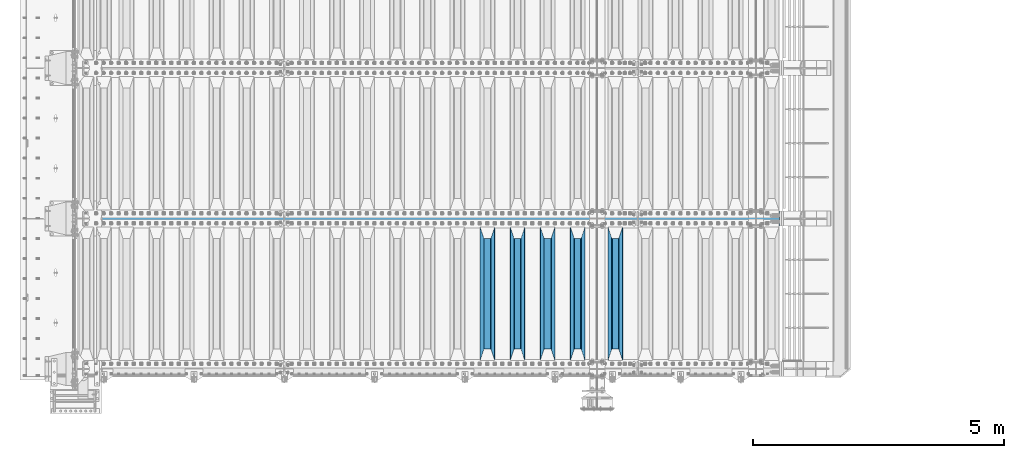
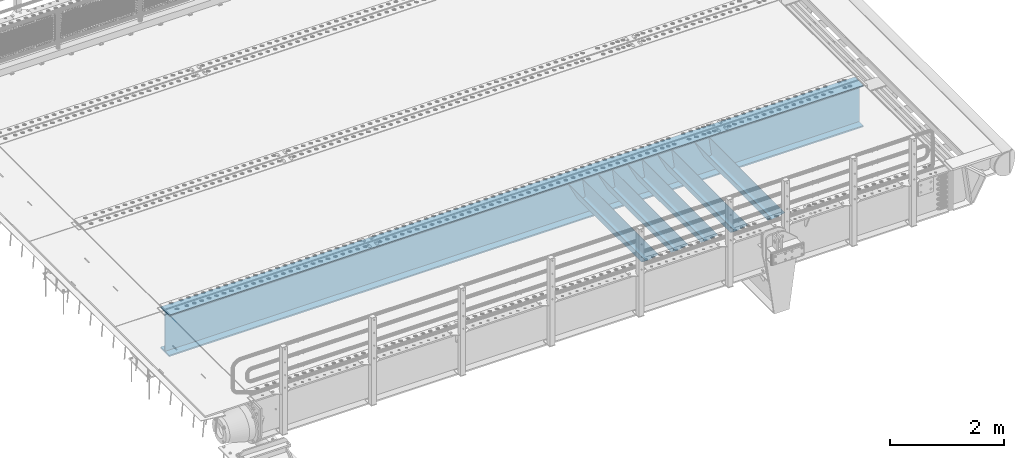
# One storey, part 106 of 240: 6 beams.
"""IFC2X3 building model written with IfcOpenShell, lengths in millimetres."""

from ifc_helpers import new_model, si_unit, frame, origin_with_axes, place, context, subcontext, project, spatial, faceted_brep, material, type_object, element, save


model = new_model("IFC2X3")

# Units and contexts
model_context = context("Model", 3, precision=1e-05, world=origin_with_axes())
body_context = subcontext(model_context, "Body", "Model", "MODEL_VIEW")
ifc_project = project(units=[si_unit("LENGTHUNIT", "METRE", prefix="MILLI"), si_unit("AREAUNIT", "SQUARE_METRE"), si_unit("VOLUMEUNIT", "CUBIC_METRE"), si_unit("MASSUNIT", "GRAM", prefix="KILO"), si_unit("TIMEUNIT", "SECOND"), si_unit("PLANEANGLEUNIT", "RADIAN"), si_unit("SOLIDANGLEUNIT", "STERADIAN"), si_unit("THERMODYNAMICTEMPERATUREUNIT", "DEGREE_CELSIUS"), si_unit("LUMINOUSINTENSITYUNIT", "LUMEN")], contexts=[model_context])

# Site, building, storey
site_placement = place(None, origin_with_axes())
site = spatial("IfcSite", under=ifc_project, at=site_placement, CompositionType="ELEMENT")
building_placement = place(site_placement, origin_with_axes())
building = spatial("IfcBuilding", under=site, at=building_placement, Name="Standard", CompositionType="ELEMENT")
storey_placement = place(building_placement, origin_with_axes())
storey = spatial("IfcBuildingStorey", under=building, at=storey_placement, Name="Undefined", CompositionType="ELEMENT", Elevation=0.0)

# Beams
ifc_material = material(Name="STEEL/S355N")
beam_type_1 = type_object("IfcBeamType", PredefinedType="NOTDEFINED")
beam_1_placement = place(storey_placement, frame((53200.0, 24175.0, -115.0), z_axis=(0.0, 0.0, 1.0), x_axis=(0.0, 1.0, 0.0)))
element("IfcBeam", 1, at=beam_1_placement, inside=storey, type_object=beam_type_1, material=ifc_material, context=body_context, shape_type="Brep", body=[
    faceted_brep([(0.0, 150.0, 115.0), (0.0, 143.690000000002, 115.0), (2650.00000000297, 143.690000000002, 115.0), (2650.00000000297, 150.0, 115.0), (2650.00000000297, 142.059565218406, 110.000000003094), (2650.00000000297, 148.369565218403, 110.000000003094), (2441.90079219209, -80.1103600731149, -98.0992078077845), (2437.7588105432, -77.5672621345584, -102.241189456673), (2434.06523489747, -74.4080125315522, -105.934765102404), (2430.9108609509, -70.7102721255724, -109.089139048974), (2428.37322971128, -66.5649389910031, -111.626770288588), (2426.51472138055, -62.0739139532889, -113.485278619323), (2425.38102192092, -57.3475956567636, -114.618978078955), (2424.99999999987, -52.5021667386536, -115.0), (2424.99999999987, 52.5021667386536, -115.0), (2425.38102192092, 57.3475956567636, -114.618978078955), (2426.51472138055, 62.0739139532889, -113.485278619323), (2428.37322971128, 66.5649389910031, -111.626770288588), (2430.9108609509, 70.7102721255724, -109.089139048974), (2434.06523489747, 74.4080125315522, -105.934765102404), (2437.7588105432, 77.5672621345584, -102.241189456673), (2441.90079219209, 80.1103600731149, -98.0992078077846), (2446.38936140512, 81.9747917625791, -93.6106385947584), (2448.2494850041, 76.2713538057287, -91.7505149957729), (2444.62967112263, 74.76777986261, -95.3703288772456), (2441.28936334127, 72.7168944282894, -98.710636658607), (2438.31067330439, 70.1691124903809, -101.689326695487), (2435.76682334748, 67.1870637758839, -104.233176652398), (2433.72034654134, 63.8440531834931, -106.279653458539), (2432.22154950042, 60.2222587982324, -107.778450499454), (2431.30727574265, 56.4107117849126, -108.692724257221), (2430.99999999987, 52.5031078186876, -109.0), (2430.99999999987, -52.5031078186876, -109.0), (2431.30727574265, -56.4107117849126, -108.692724257221), (2432.22154950042, -60.2222587982324, -107.778450499454), (2433.72034654134, -63.8440531834931, -106.279653458539), (2435.76682334748, -67.1870637758839, -104.233176652398), (2438.31067330439, -70.1691124903809, -101.689326695487), (2441.28936334127, -72.7168944282894, -98.7106366586071), (2444.62967112263, -74.76777986261, -95.3703288772457), (2448.2494850041, -76.2713538057287, -91.7505149957729), (2650.00000000297, -142.059565218406, 110.000000003094), (2650.00000000297, -148.369565218403, 110.000000003094), (2446.38936140512, -81.9747917625791, -93.6106385947584), (2650.00000000297, -143.690000000002, 115.0), (2650.00000000297, -150.0, 115.0), (0.0, -143.690000000002, 115.0), (0.0, -150.0, 115.0), (0.0, -148.369565218258, 110.000000002667), (203.610638597427, -81.9747917625791, -93.6106385947584), (208.09920781045, -80.1103600731149, -98.0992078077845), (212.241189459342, -77.5672621345584, -102.241189456673), (215.93476510507, -74.4080125315522, -105.934765102404), (219.089139051641, -70.7102721255724, -109.089139048974), (221.626770291256, -66.5649389910031, -111.626770288588), (223.485278621989, -62.0739139532889, -113.485278619323), (224.618978081624, -57.3475956567636, -114.618978078955), (225.000000002663, -52.5021667386536, -115.0), (225.000000002663, 52.5021667386536, -115.0), (224.618978081624, 57.3475956567636, -114.618978078955), (223.485278621989, 62.0739139532889, -113.485278619323), (221.626770291256, 66.5649389910031, -111.626770288588), (219.089139051641, 70.7102721255724, -109.089139048974), (215.93476510507, 74.4080125315522, -105.934765102404), (212.241189459342, 77.5672621345584, -102.241189456673), (208.09920781045, 80.1103600731149, -98.0992078077846), (203.610638597427, 81.9747917625791, -93.6106385947584), (0.0, 148.369565218258, 110.000000002667), (0.0, 142.05956521826, 110.000000002667), (201.750514998439, 76.2713538057287, -91.7505149957729), (205.370328879908, 74.76777986261, -95.3703288772456), (208.710636661275, 72.7168944282894, -98.710636658607), (211.689326698153, 70.1691124903809, -101.689326695487), (214.233176655063, 67.1870637758839, -104.233176652398), (216.279653461206, 63.8440531834931, -106.279653458539), (217.778450502123, 60.2222587982324, -107.778450499454), (218.692724259887, 56.4107117849126, -108.692724257221), (219.000000002667, 52.5031078186876, -109.0), (219.000000002667, -52.5031078186876, -109.0), (218.692724259887, -56.4107117849126, -108.692724257221), (217.778450502123, -60.2222587982324, -107.778450499454), (216.279653461206, -63.8440531834931, -106.279653458539), (214.233176655063, -67.1870637758839, -104.233176652398), (211.689326698153, -70.1691124903809, -101.689326695487), (208.710636661275, -72.7168944282894, -98.7106366586071), (205.370328879915, -74.76777986261, -95.3703288772457), (201.750514998439, -76.2713538057287, -91.7505149957729), (0.0, -142.05956521826, 110.000000002667)], [[[0, 1, 2, 3]], [[3, 2, 4, 5]], [[6, 7, 8, 9, 10, 11, 12, 13, 14, 15, 16, 17, 18, 19, 20, 21, 22, 5, 4, 23, 24, 25, 26, 27, 28, 29, 30, 31, 32, 33, 34, 35, 36, 37, 38, 39, 40, 41, 42, 43]], [[44, 45, 42, 41]], [[46, 47, 45, 44]], [[43, 42, 45, 47, 48, 49]], [[6, 43, 49, 50]], [[7, 6, 50, 51]], [[8, 7, 51, 52]], [[9, 8, 52, 53]], [[10, 9, 53, 54]], [[11, 10, 54, 55]], [[12, 11, 55, 56]], [[13, 12, 56, 57]], [[14, 13, 57, 58]], [[15, 14, 58, 59]], [[16, 15, 59, 60]], [[17, 16, 60, 61]], [[18, 17, 61, 62]], [[19, 18, 62, 63]], [[20, 19, 63, 64]], [[21, 20, 64, 65]], [[22, 21, 65, 66]], [[0, 3, 5, 22, 66, 67]], [[1, 0, 67, 68]], [[23, 4, 2, 1, 68, 69]], [[24, 23, 69, 70]], [[25, 24, 70, 71]], [[26, 25, 71, 72]], [[27, 26, 72, 73]], [[28, 27, 73, 74]], [[29, 28, 74, 75]], [[30, 29, 75, 76]], [[31, 30, 76, 77]], [[32, 31, 77, 78]], [[33, 32, 78, 79]], [[34, 33, 79, 80]], [[35, 34, 80, 81]], [[36, 35, 81, 82]], [[37, 36, 82, 83]], [[38, 37, 83, 84]], [[39, 38, 84, 85]], [[40, 39, 85, 86]], [[46, 44, 41, 40, 86, 87]], [[47, 46, 87, 48]], [[86, 85, 84, 83, 82, 81, 80, 79, 78, 77, 76, 75, 74, 73, 72, 71, 70, 69, 68, 67, 66, 65, 64, 63, 62, 61, 60, 59, 58, 57, 56, 55, 54, 53, 52, 51, 50, 49, 48, 87]]]),
])
beam_2_placement = place(storey_placement, frame((52450.0, 24175.0, -115.0), z_axis=(0.0, 0.0, 1.0), x_axis=(0.0, 1.0, 0.0)))
element("IfcBeam", 2, at=beam_2_placement, inside=storey, type_object=beam_type_1, material=ifc_material, context=body_context, shape_type="Brep", body=[
    faceted_brep([(0.0, 150.0, 115.0), (0.0, 143.690000000002, 115.0), (2650.00000000297, 143.690000000002, 115.0), (2650.00000000297, 150.0, 115.0), (2650.00000000297, 142.059565218406, 110.000000003094), (2650.00000000297, 148.369565218403, 110.000000003094), (2441.90079219209, -80.1103600731149, -98.0992078077845), (2437.7588105432, -77.5672621345584, -102.241189456673), (2434.06523489747, -74.4080125315522, -105.934765102404), (2430.9108609509, -70.7102721255724, -109.089139048974), (2428.37322971128, -66.5649389910031, -111.626770288588), (2426.51472138055, -62.0739139532889, -113.485278619323), (2425.38102192092, -57.3475956567636, -114.618978078955), (2424.99999999987, -52.5021667386536, -115.0), (2424.99999999987, 52.5021667386536, -115.0), (2425.38102192092, 57.3475956567636, -114.618978078955), (2426.51472138055, 62.0739139532889, -113.485278619323), (2428.37322971128, 66.5649389910031, -111.626770288588), (2430.9108609509, 70.7102721255724, -109.089139048974), (2434.06523489747, 74.4080125315522, -105.934765102404), (2437.7588105432, 77.5672621345584, -102.241189456673), (2441.90079219209, 80.1103600731149, -98.0992078077846), (2446.38936140512, 81.9747917625791, -93.6106385947584), (2448.2494850041, 76.2713538057287, -91.7505149957729), (2444.62967112263, 74.76777986261, -95.3703288772456), (2441.28936334127, 72.7168944282894, -98.710636658607), (2438.31067330439, 70.1691124903809, -101.689326695487), (2435.76682334748, 67.1870637758839, -104.233176652398), (2433.72034654134, 63.8440531834931, -106.279653458539), (2432.22154950042, 60.2222587982324, -107.778450499454), (2431.30727574265, 56.4107117849126, -108.692724257221), (2430.99999999987, 52.5031078186876, -109.0), (2430.99999999987, -52.5031078186876, -109.0), (2431.30727574265, -56.4107117849126, -108.692724257221), (2432.22154950042, -60.2222587982324, -107.778450499454), (2433.72034654134, -63.8440531834931, -106.279653458539), (2435.76682334748, -67.1870637758839, -104.233176652398), (2438.31067330439, -70.1691124903809, -101.689326695487), (2441.28936334127, -72.7168944282894, -98.7106366586071), (2444.62967112263, -74.76777986261, -95.3703288772457), (2448.2494850041, -76.2713538057287, -91.7505149957729), (2650.00000000297, -142.059565218406, 110.000000003094), (2650.00000000297, -148.369565218403, 110.000000003094), (2446.38936140512, -81.9747917625791, -93.6106385947584), (2650.00000000297, -143.690000000002, 115.0), (2650.00000000297, -150.0, 115.0), (0.0, -143.690000000002, 115.0), (0.0, -150.0, 115.0), (0.0, -148.369565218258, 110.000000002667), (203.610638597427, -81.9747917625791, -93.6106385947584), (208.09920781045, -80.1103600731149, -98.0992078077845), (212.241189459342, -77.5672621345584, -102.241189456673), (215.93476510507, -74.4080125315522, -105.934765102404), (219.089139051641, -70.7102721255724, -109.089139048974), (221.626770291256, -66.5649389910031, -111.626770288588), (223.485278621989, -62.0739139532889, -113.485278619323), (224.618978081624, -57.3475956567636, -114.618978078955), (225.000000002663, -52.5021667386536, -115.0), (225.000000002663, 52.5021667386536, -115.0), (224.618978081624, 57.3475956567636, -114.618978078955), (223.485278621989, 62.0739139532889, -113.485278619323), (221.626770291256, 66.5649389910031, -111.626770288588), (219.089139051641, 70.7102721255724, -109.089139048974), (215.93476510507, 74.4080125315522, -105.934765102404), (212.241189459342, 77.5672621345584, -102.241189456673), (208.09920781045, 80.1103600731149, -98.0992078077846), (203.610638597427, 81.9747917625791, -93.6106385947584), (0.0, 148.369565218258, 110.000000002667), (0.0, 142.05956521826, 110.000000002667), (201.750514998439, 76.2713538057287, -91.7505149957729), (205.370328879908, 74.76777986261, -95.3703288772456), (208.710636661275, 72.7168944282894, -98.710636658607), (211.689326698153, 70.1691124903809, -101.689326695487), (214.233176655063, 67.1870637758839, -104.233176652398), (216.279653461206, 63.8440531834931, -106.279653458539), (217.778450502123, 60.2222587982324, -107.778450499454), (218.692724259887, 56.4107117849126, -108.692724257221), (219.000000002667, 52.5031078186876, -109.0), (219.000000002667, -52.5031078186876, -109.0), (218.692724259887, -56.4107117849126, -108.692724257221), (217.778450502123, -60.2222587982324, -107.778450499454), (216.279653461206, -63.8440531834931, -106.279653458539), (214.233176655063, -67.1870637758839, -104.233176652398), (211.689326698153, -70.1691124903809, -101.689326695487), (208.710636661275, -72.7168944282894, -98.7106366586071), (205.370328879915, -74.76777986261, -95.3703288772457), (201.750514998439, -76.2713538057287, -91.7505149957729), (0.0, -142.05956521826, 110.000000002667)], [[[0, 1, 2, 3]], [[3, 2, 4, 5]], [[6, 7, 8, 9, 10, 11, 12, 13, 14, 15, 16, 17, 18, 19, 20, 21, 22, 5, 4, 23, 24, 25, 26, 27, 28, 29, 30, 31, 32, 33, 34, 35, 36, 37, 38, 39, 40, 41, 42, 43]], [[44, 45, 42, 41]], [[46, 47, 45, 44]], [[43, 42, 45, 47, 48, 49]], [[6, 43, 49, 50]], [[7, 6, 50, 51]], [[8, 7, 51, 52]], [[9, 8, 52, 53]], [[10, 9, 53, 54]], [[11, 10, 54, 55]], [[12, 11, 55, 56]], [[13, 12, 56, 57]], [[14, 13, 57, 58]], [[15, 14, 58, 59]], [[16, 15, 59, 60]], [[17, 16, 60, 61]], [[18, 17, 61, 62]], [[19, 18, 62, 63]], [[20, 19, 63, 64]], [[21, 20, 64, 65]], [[22, 21, 65, 66]], [[0, 3, 5, 22, 66, 67]], [[1, 0, 67, 68]], [[23, 4, 2, 1, 68, 69]], [[24, 23, 69, 70]], [[25, 24, 70, 71]], [[26, 25, 71, 72]], [[27, 26, 72, 73]], [[28, 27, 73, 74]], [[29, 28, 74, 75]], [[30, 29, 75, 76]], [[31, 30, 76, 77]], [[32, 31, 77, 78]], [[33, 32, 78, 79]], [[34, 33, 79, 80]], [[35, 34, 80, 81]], [[36, 35, 81, 82]], [[37, 36, 82, 83]], [[38, 37, 83, 84]], [[39, 38, 84, 85]], [[40, 39, 85, 86]], [[46, 44, 41, 40, 86, 87]], [[47, 46, 87, 48]], [[86, 85, 84, 83, 82, 81, 80, 79, 78, 77, 76, 75, 74, 73, 72, 71, 70, 69, 68, 67, 66, 65, 64, 63, 62, 61, 60, 59, 58, 57, 56, 55, 54, 53, 52, 51, 50, 49, 48, 87]]]),
])
beam_3_placement = place(storey_placement, frame((51850.0, 24175.0, -115.0), z_axis=(0.0, 0.0, 1.0), x_axis=(0.0, 1.0, 0.0)))
element("IfcBeam", 3, at=beam_3_placement, inside=storey, type_object=beam_type_1, material=ifc_material, context=body_context, shape_type="Brep", body=[
    faceted_brep([(0.0, 150.0, 115.0), (0.0, 143.690000000002, 115.0), (2650.00000000297, 143.690000000002, 115.0), (2650.00000000297, 150.0, 115.0), (2650.00000000297, 142.059565218406, 110.000000003094), (2650.00000000297, 148.369565218403, 110.000000003094), (2441.90079219209, -80.1103600731149, -98.0992078077845), (2437.7588105432, -77.5672621345584, -102.241189456673), (2434.06523489747, -74.4080125315522, -105.934765102404), (2430.9108609509, -70.7102721255724, -109.089139048974), (2428.37322971128, -66.5649389910031, -111.626770288588), (2426.51472138055, -62.0739139532889, -113.485278619323), (2425.38102192092, -57.3475956567636, -114.618978078955), (2424.99999999987, -52.5021667386536, -115.0), (2424.99999999987, 52.5021667386536, -115.0), (2425.38102192092, 57.3475956567636, -114.618978078955), (2426.51472138055, 62.0739139532889, -113.485278619323), (2428.37322971128, 66.5649389910031, -111.626770288588), (2430.9108609509, 70.7102721255724, -109.089139048974), (2434.06523489747, 74.4080125315522, -105.934765102404), (2437.7588105432, 77.5672621345584, -102.241189456673), (2441.90079219209, 80.1103600731149, -98.0992078077846), (2446.38936140512, 81.9747917625791, -93.6106385947584), (2448.2494850041, 76.2713538057287, -91.7505149957729), (2444.62967112263, 74.76777986261, -95.3703288772456), (2441.28936334127, 72.7168944282894, -98.710636658607), (2438.31067330439, 70.1691124903809, -101.689326695487), (2435.76682334748, 67.1870637758839, -104.233176652398), (2433.72034654134, 63.8440531834931, -106.279653458539), (2432.22154950042, 60.2222587982324, -107.778450499454), (2431.30727574265, 56.4107117849126, -108.692724257221), (2430.99999999987, 52.5031078186876, -109.0), (2430.99999999987, -52.5031078186876, -109.0), (2431.30727574265, -56.4107117849126, -108.692724257221), (2432.22154950042, -60.2222587982324, -107.778450499454), (2433.72034654134, -63.8440531834931, -106.279653458539), (2435.76682334748, -67.1870637758839, -104.233176652398), (2438.31067330439, -70.1691124903809, -101.689326695487), (2441.28936334127, -72.7168944282894, -98.7106366586071), (2444.62967112263, -74.76777986261, -95.3703288772457), (2448.2494850041, -76.2713538057287, -91.7505149957729), (2650.00000000297, -142.059565218406, 110.000000003094), (2650.00000000297, -148.369565218403, 110.000000003094), (2446.38936140512, -81.9747917625791, -93.6106385947584), (2650.00000000297, -143.690000000002, 115.0), (2650.00000000297, -150.0, 115.0), (0.0, -143.690000000002, 115.0), (0.0, -150.0, 115.0), (0.0, -148.369565218258, 110.000000002667), (203.610638597427, -81.9747917625791, -93.6106385947584), (208.09920781045, -80.1103600731149, -98.0992078077845), (212.241189459342, -77.5672621345584, -102.241189456673), (215.93476510507, -74.4080125315522, -105.934765102404), (219.089139051641, -70.7102721255724, -109.089139048974), (221.626770291256, -66.5649389910031, -111.626770288588), (223.485278621989, -62.0739139532889, -113.485278619323), (224.618978081624, -57.3475956567636, -114.618978078955), (225.000000002663, -52.5021667386536, -115.0), (225.000000002663, 52.5021667386536, -115.0), (224.618978081624, 57.3475956567636, -114.618978078955), (223.485278621989, 62.0739139532889, -113.485278619323), (221.626770291256, 66.5649389910031, -111.626770288588), (219.089139051641, 70.7102721255724, -109.089139048974), (215.93476510507, 74.4080125315522, -105.934765102404), (212.241189459342, 77.5672621345584, -102.241189456673), (208.09920781045, 80.1103600731149, -98.0992078077846), (203.610638597427, 81.9747917625791, -93.6106385947584), (0.0, 148.369565218258, 110.000000002667), (0.0, 142.05956521826, 110.000000002667), (201.750514998439, 76.2713538057287, -91.7505149957729), (205.370328879908, 74.76777986261, -95.3703288772456), (208.710636661275, 72.7168944282894, -98.710636658607), (211.689326698153, 70.1691124903809, -101.689326695487), (214.233176655063, 67.1870637758839, -104.233176652398), (216.279653461206, 63.8440531834931, -106.279653458539), (217.778450502123, 60.2222587982324, -107.778450499454), (218.692724259887, 56.4107117849126, -108.692724257221), (219.000000002667, 52.5031078186876, -109.0), (219.000000002667, -52.5031078186876, -109.0), (218.692724259887, -56.4107117849126, -108.692724257221), (217.778450502123, -60.2222587982324, -107.778450499454), (216.279653461206, -63.8440531834931, -106.279653458539), (214.233176655063, -67.1870637758839, -104.233176652398), (211.689326698153, -70.1691124903809, -101.689326695487), (208.710636661275, -72.7168944282894, -98.7106366586071), (205.370328879915, -74.76777986261, -95.3703288772457), (201.750514998439, -76.2713538057287, -91.7505149957729), (0.0, -142.05956521826, 110.000000002667)], [[[0, 1, 2, 3]], [[3, 2, 4, 5]], [[6, 7, 8, 9, 10, 11, 12, 13, 14, 15, 16, 17, 18, 19, 20, 21, 22, 5, 4, 23, 24, 25, 26, 27, 28, 29, 30, 31, 32, 33, 34, 35, 36, 37, 38, 39, 40, 41, 42, 43]], [[44, 45, 42, 41]], [[46, 47, 45, 44]], [[43, 42, 45, 47, 48, 49]], [[6, 43, 49, 50]], [[7, 6, 50, 51]], [[8, 7, 51, 52]], [[9, 8, 52, 53]], [[10, 9, 53, 54]], [[11, 10, 54, 55]], [[12, 11, 55, 56]], [[13, 12, 56, 57]], [[14, 13, 57, 58]], [[15, 14, 58, 59]], [[16, 15, 59, 60]], [[17, 16, 60, 61]], [[18, 17, 61, 62]], [[19, 18, 62, 63]], [[20, 19, 63, 64]], [[21, 20, 64, 65]], [[22, 21, 65, 66]], [[0, 3, 5, 22, 66, 67]], [[1, 0, 67, 68]], [[23, 4, 2, 1, 68, 69]], [[24, 23, 69, 70]], [[25, 24, 70, 71]], [[26, 25, 71, 72]], [[27, 26, 72, 73]], [[28, 27, 73, 74]], [[29, 28, 74, 75]], [[30, 29, 75, 76]], [[31, 30, 76, 77]], [[32, 31, 77, 78]], [[33, 32, 78, 79]], [[34, 33, 79, 80]], [[35, 34, 80, 81]], [[36, 35, 81, 82]], [[37, 36, 82, 83]], [[38, 37, 83, 84]], [[39, 38, 84, 85]], [[40, 39, 85, 86]], [[46, 44, 41, 40, 86, 87]], [[47, 46, 87, 48]], [[86, 85, 84, 83, 82, 81, 80, 79, 78, 77, 76, 75, 74, 73, 72, 71, 70, 69, 68, 67, 66, 65, 64, 63, 62, 61, 60, 59, 58, 57, 56, 55, 54, 53, 52, 51, 50, 49, 48, 87]]]),
])
beam_4_placement = place(storey_placement, frame((51250.0, 24175.0, -115.0), z_axis=(0.0, 0.0, 1.0), x_axis=(0.0, 1.0, 0.0)))
element("IfcBeam", 4, at=beam_4_placement, inside=storey, type_object=beam_type_1, material=ifc_material, context=body_context, shape_type="Brep", body=[
    faceted_brep([(0.0, 150.0, 115.0), (0.0, 143.690000000002, 115.0), (2650.00000000297, 143.690000000002, 115.0), (2650.00000000297, 150.0, 115.0), (2650.00000000297, 142.059565218406, 110.000000003094), (2650.00000000297, 148.369565218403, 110.000000003094), (2441.90079219209, -80.1103600731149, -98.0992078077845), (2437.7588105432, -77.5672621345584, -102.241189456673), (2434.06523489747, -74.4080125315522, -105.934765102404), (2430.9108609509, -70.7102721255724, -109.089139048974), (2428.37322971128, -66.5649389910031, -111.626770288588), (2426.51472138055, -62.0739139532889, -113.485278619323), (2425.38102192092, -57.3475956567636, -114.618978078955), (2424.99999999987, -52.5021667386536, -115.0), (2424.99999999987, 52.5021667386536, -115.0), (2425.38102192092, 57.3475956567636, -114.618978078955), (2426.51472138055, 62.0739139532889, -113.485278619323), (2428.37322971128, 66.5649389910031, -111.626770288588), (2430.9108609509, 70.7102721255724, -109.089139048974), (2434.06523489747, 74.4080125315522, -105.934765102404), (2437.7588105432, 77.5672621345584, -102.241189456673), (2441.90079219209, 80.1103600731149, -98.0992078077846), (2446.38936140512, 81.9747917625791, -93.6106385947584), (2448.2494850041, 76.2713538057287, -91.7505149957729), (2444.62967112263, 74.76777986261, -95.3703288772456), (2441.28936334127, 72.7168944282894, -98.710636658607), (2438.31067330439, 70.1691124903809, -101.689326695487), (2435.76682334748, 67.1870637758839, -104.233176652398), (2433.72034654134, 63.8440531834931, -106.279653458539), (2432.22154950042, 60.2222587982324, -107.778450499454), (2431.30727574265, 56.4107117849126, -108.692724257221), (2430.99999999987, 52.5031078186876, -109.0), (2430.99999999987, -52.5031078186876, -109.0), (2431.30727574265, -56.4107117849126, -108.692724257221), (2432.22154950042, -60.2222587982324, -107.778450499454), (2433.72034654134, -63.8440531834931, -106.279653458539), (2435.76682334748, -67.1870637758839, -104.233176652398), (2438.31067330439, -70.1691124903809, -101.689326695487), (2441.28936334127, -72.7168944282894, -98.7106366586071), (2444.62967112263, -74.76777986261, -95.3703288772457), (2448.2494850041, -76.2713538057287, -91.7505149957729), (2650.00000000297, -142.059565218406, 110.000000003094), (2650.00000000297, -148.369565218403, 110.000000003094), (2446.38936140512, -81.9747917625791, -93.6106385947584), (2650.00000000297, -143.690000000002, 115.0), (2650.00000000297, -150.0, 115.0), (0.0, -143.690000000002, 115.0), (0.0, -150.0, 115.0), (0.0, -148.369565218258, 110.000000002667), (203.610638597427, -81.9747917625791, -93.6106385947584), (208.09920781045, -80.1103600731149, -98.0992078077845), (212.241189459342, -77.5672621345584, -102.241189456673), (215.93476510507, -74.4080125315522, -105.934765102404), (219.089139051641, -70.7102721255724, -109.089139048974), (221.626770291256, -66.5649389910031, -111.626770288588), (223.485278621989, -62.0739139532889, -113.485278619323), (224.618978081624, -57.3475956567636, -114.618978078955), (225.000000002663, -52.5021667386536, -115.0), (225.000000002663, 52.5021667386536, -115.0), (224.618978081624, 57.3475956567636, -114.618978078955), (223.485278621989, 62.0739139532889, -113.485278619323), (221.626770291256, 66.5649389910031, -111.626770288588), (219.089139051641, 70.7102721255724, -109.089139048974), (215.93476510507, 74.4080125315522, -105.934765102404), (212.241189459342, 77.5672621345584, -102.241189456673), (208.09920781045, 80.1103600731149, -98.0992078077846), (203.610638597427, 81.9747917625791, -93.6106385947584), (0.0, 148.369565218258, 110.000000002667), (0.0, 142.05956521826, 110.000000002667), (201.750514998439, 76.2713538057287, -91.7505149957729), (205.370328879908, 74.76777986261, -95.3703288772456), (208.710636661275, 72.7168944282894, -98.710636658607), (211.689326698153, 70.1691124903809, -101.689326695487), (214.233176655063, 67.1870637758839, -104.233176652398), (216.279653461206, 63.8440531834931, -106.279653458539), (217.778450502123, 60.2222587982324, -107.778450499454), (218.692724259887, 56.4107117849126, -108.692724257221), (219.000000002667, 52.5031078186876, -109.0), (219.000000002667, -52.5031078186876, -109.0), (218.692724259887, -56.4107117849126, -108.692724257221), (217.778450502123, -60.2222587982324, -107.778450499454), (216.279653461206, -63.8440531834931, -106.279653458539), (214.233176655063, -67.1870637758839, -104.233176652398), (211.689326698153, -70.1691124903809, -101.689326695487), (208.710636661275, -72.7168944282894, -98.7106366586071), (205.370328879915, -74.76777986261, -95.3703288772457), (201.750514998439, -76.2713538057287, -91.7505149957729), (0.0, -142.05956521826, 110.000000002667)], [[[0, 1, 2, 3]], [[3, 2, 4, 5]], [[6, 7, 8, 9, 10, 11, 12, 13, 14, 15, 16, 17, 18, 19, 20, 21, 22, 5, 4, 23, 24, 25, 26, 27, 28, 29, 30, 31, 32, 33, 34, 35, 36, 37, 38, 39, 40, 41, 42, 43]], [[44, 45, 42, 41]], [[46, 47, 45, 44]], [[43, 42, 45, 47, 48, 49]], [[6, 43, 49, 50]], [[7, 6, 50, 51]], [[8, 7, 51, 52]], [[9, 8, 52, 53]], [[10, 9, 53, 54]], [[11, 10, 54, 55]], [[12, 11, 55, 56]], [[13, 12, 56, 57]], [[14, 13, 57, 58]], [[15, 14, 58, 59]], [[16, 15, 59, 60]], [[17, 16, 60, 61]], [[18, 17, 61, 62]], [[19, 18, 62, 63]], [[20, 19, 63, 64]], [[21, 20, 64, 65]], [[22, 21, 65, 66]], [[0, 3, 5, 22, 66, 67]], [[1, 0, 67, 68]], [[23, 4, 2, 1, 68, 69]], [[24, 23, 69, 70]], [[25, 24, 70, 71]], [[26, 25, 71, 72]], [[27, 26, 72, 73]], [[28, 27, 73, 74]], [[29, 28, 74, 75]], [[30, 29, 75, 76]], [[31, 30, 76, 77]], [[32, 31, 77, 78]], [[33, 32, 78, 79]], [[34, 33, 79, 80]], [[35, 34, 80, 81]], [[36, 35, 81, 82]], [[37, 36, 82, 83]], [[38, 37, 83, 84]], [[39, 38, 84, 85]], [[40, 39, 85, 86]], [[46, 44, 41, 40, 86, 87]], [[47, 46, 87, 48]], [[86, 85, 84, 83, 82, 81, 80, 79, 78, 77, 76, 75, 74, 73, 72, 71, 70, 69, 68, 67, 66, 65, 64, 63, 62, 61, 60, 59, 58, 57, 56, 55, 54, 53, 52, 51, 50, 49, 48, 87]]]),
])
beam_5_placement = place(storey_placement, frame((50650.0, 24175.0, -115.0), z_axis=(0.0, 0.0, 1.0), x_axis=(0.0, 1.0, 0.0)))
element("IfcBeam", 5, at=beam_5_placement, inside=storey, type_object=beam_type_1, material=ifc_material, context=body_context, shape_type="Brep", body=[
    faceted_brep([(0.0, 150.0, 115.0), (0.0, 143.690000000002, 115.0), (2650.00000000297, 143.690000000002, 115.0), (2650.00000000297, 150.0, 115.0), (2650.00000000297, 142.059565218406, 110.000000003094), (2650.00000000297, 148.369565218403, 110.000000003094), (2441.90079219209, -80.1103600731149, -98.0992078077845), (2437.7588105432, -77.5672621345584, -102.241189456673), (2434.06523489747, -74.4080125315522, -105.934765102404), (2430.9108609509, -70.7102721255724, -109.089139048974), (2428.37322971128, -66.5649389910031, -111.626770288588), (2426.51472138055, -62.0739139532889, -113.485278619323), (2425.38102192092, -57.3475956567636, -114.618978078955), (2424.99999999987, -52.5021667386536, -115.0), (2424.99999999987, 52.5021667386536, -115.0), (2425.38102192092, 57.3475956567636, -114.618978078955), (2426.51472138055, 62.0739139532889, -113.485278619323), (2428.37322971128, 66.5649389910031, -111.626770288588), (2430.9108609509, 70.7102721255724, -109.089139048974), (2434.06523489747, 74.4080125315522, -105.934765102404), (2437.7588105432, 77.5672621345584, -102.241189456673), (2441.90079219209, 80.1103600731149, -98.0992078077846), (2446.38936140512, 81.9747917625791, -93.6106385947584), (2448.2494850041, 76.2713538057287, -91.7505149957729), (2444.62967112263, 74.76777986261, -95.3703288772456), (2441.28936334127, 72.7168944282894, -98.710636658607), (2438.31067330439, 70.1691124903809, -101.689326695487), (2435.76682334748, 67.1870637758839, -104.233176652398), (2433.72034654134, 63.8440531834931, -106.279653458539), (2432.22154950042, 60.2222587982324, -107.778450499454), (2431.30727574265, 56.4107117849126, -108.692724257221), (2430.99999999987, 52.5031078186876, -109.0), (2430.99999999987, -52.5031078186876, -109.0), (2431.30727574265, -56.4107117849126, -108.692724257221), (2432.22154950042, -60.2222587982324, -107.778450499454), (2433.72034654134, -63.8440531834931, -106.279653458539), (2435.76682334748, -67.1870637758839, -104.233176652398), (2438.31067330439, -70.1691124903809, -101.689326695487), (2441.28936334127, -72.7168944282894, -98.7106366586071), (2444.62967112263, -74.76777986261, -95.3703288772457), (2448.2494850041, -76.2713538057287, -91.7505149957729), (2650.00000000297, -142.059565218406, 110.000000003094), (2650.00000000297, -148.369565218403, 110.000000003094), (2446.38936140512, -81.9747917625791, -93.6106385947584), (2650.00000000297, -143.690000000002, 115.0), (2650.00000000297, -150.0, 115.0), (0.0, -143.690000000002, 115.0), (0.0, -150.0, 115.0), (0.0, -148.369565218258, 110.000000002667), (203.610638597427, -81.9747917625791, -93.6106385947584), (208.09920781045, -80.1103600731149, -98.0992078077845), (212.241189459342, -77.5672621345584, -102.241189456673), (215.93476510507, -74.4080125315522, -105.934765102404), (219.089139051641, -70.7102721255724, -109.089139048974), (221.626770291256, -66.5649389910031, -111.626770288588), (223.485278621989, -62.0739139532889, -113.485278619323), (224.618978081624, -57.3475956567636, -114.618978078955), (225.000000002663, -52.5021667386536, -115.0), (225.000000002663, 52.5021667386536, -115.0), (224.618978081624, 57.3475956567636, -114.618978078955), (223.485278621989, 62.0739139532889, -113.485278619323), (221.626770291256, 66.5649389910031, -111.626770288588), (219.089139051641, 70.7102721255724, -109.089139048974), (215.93476510507, 74.4080125315522, -105.934765102404), (212.241189459342, 77.5672621345584, -102.241189456673), (208.09920781045, 80.1103600731149, -98.0992078077846), (203.610638597427, 81.9747917625791, -93.6106385947584), (0.0, 148.369565218258, 110.000000002667), (0.0, 142.05956521826, 110.000000002667), (201.750514998439, 76.2713538057287, -91.7505149957729), (205.370328879908, 74.76777986261, -95.3703288772456), (208.710636661275, 72.7168944282894, -98.710636658607), (211.689326698153, 70.1691124903809, -101.689326695487), (214.233176655063, 67.1870637758839, -104.233176652398), (216.279653461206, 63.8440531834931, -106.279653458539), (217.778450502123, 60.2222587982324, -107.778450499454), (218.692724259887, 56.4107117849126, -108.692724257221), (219.000000002667, 52.5031078186876, -109.0), (219.000000002667, -52.5031078186876, -109.0), (218.692724259887, -56.4107117849126, -108.692724257221), (217.778450502123, -60.2222587982324, -107.778450499454), (216.279653461206, -63.8440531834931, -106.279653458539), (214.233176655063, -67.1870637758839, -104.233176652398), (211.689326698153, -70.1691124903809, -101.689326695487), (208.710636661275, -72.7168944282894, -98.7106366586071), (205.370328879915, -74.76777986261, -95.3703288772457), (201.750514998439, -76.2713538057287, -91.7505149957729), (0.0, -142.05956521826, 110.000000002667)], [[[0, 1, 2, 3]], [[3, 2, 4, 5]], [[6, 7, 8, 9, 10, 11, 12, 13, 14, 15, 16, 17, 18, 19, 20, 21, 22, 5, 4, 23, 24, 25, 26, 27, 28, 29, 30, 31, 32, 33, 34, 35, 36, 37, 38, 39, 40, 41, 42, 43]], [[44, 45, 42, 41]], [[46, 47, 45, 44]], [[43, 42, 45, 47, 48, 49]], [[6, 43, 49, 50]], [[7, 6, 50, 51]], [[8, 7, 51, 52]], [[9, 8, 52, 53]], [[10, 9, 53, 54]], [[11, 10, 54, 55]], [[12, 11, 55, 56]], [[13, 12, 56, 57]], [[14, 13, 57, 58]], [[15, 14, 58, 59]], [[16, 15, 59, 60]], [[17, 16, 60, 61]], [[18, 17, 61, 62]], [[19, 18, 62, 63]], [[20, 19, 63, 64]], [[21, 20, 64, 65]], [[22, 21, 65, 66]], [[0, 3, 5, 22, 66, 67]], [[1, 0, 67, 68]], [[23, 4, 2, 1, 68, 69]], [[24, 23, 69, 70]], [[25, 24, 70, 71]], [[26, 25, 71, 72]], [[27, 26, 72, 73]], [[28, 27, 73, 74]], [[29, 28, 74, 75]], [[30, 29, 75, 76]], [[31, 30, 76, 77]], [[32, 31, 77, 78]], [[33, 32, 78, 79]], [[34, 33, 79, 80]], [[35, 34, 80, 81]], [[36, 35, 81, 82]], [[37, 36, 82, 83]], [[38, 37, 83, 84]], [[39, 38, 84, 85]], [[40, 39, 85, 86]], [[46, 44, 41, 40, 86, 87]], [[47, 46, 87, 48]], [[86, 85, 84, 83, 82, 81, 80, 79, 78, 77, 76, 75, 74, 73, 72, 71, 70, 69, 68, 67, 66, 65, 64, 63, 62, 61, 60, 59, 58, 57, 56, 55, 54, 53, 52, 51, 50, 49, 48, 87]]]),
])
beam_type_2 = type_object("IfcBeamType", Name="HEA900", PredefinedType="NOTDEFINED")
beam_6_placement = place(storey_placement, frame((42460.0, 27000.0, -445.0), z_axis=(0.0, 0.0, 1.0), x_axis=(1.0, 0.0, 0.0)))
element("IfcBeam", 6, at=beam_6_placement, inside=storey, type_object=beam_type_2, material=ifc_material, ObjectType="HEA900", context=body_context, shape_type="Brep", body=[
    faceted_brep([(0.0, 150.0, -445.0), (0.0, 150.0, -415.0), (14017.0, 150.0, -415.0), (14017.0, 150.0, -445.0), (0.0, 8.0, -415.0), (14017.0, 8.0, -415.0), (0.0, 8.0, 415.0), (14017.0, 8.0, 415.0), (0.0, 150.0, 415.0), (14017.0, 150.0, 415.0), (0.0, 150.0, 445.0), (14017.0, 150.0, 445.0), (0.0, -150.0, 445.0), (14017.0, -150.0, 445.0), (0.0, -150.0, 415.0), (14017.0, -150.0, 415.0), (0.0, -8.0, 415.0), (14017.0, -8.0, 415.0), (0.0, -8.0, -415.0), (14017.0, -8.0, -415.0), (0.0, -150.0, -415.0), (14017.0, -150.0, -415.0), (0.0, -150.0, -445.0), (14017.0, -150.0, -445.0)], [[[0, 1, 2, 3]], [[1, 4, 5, 2]], [[4, 6, 7, 5]], [[6, 8, 9, 7]], [[8, 10, 11, 9]], [[10, 12, 13, 11]], [[12, 14, 15, 13]], [[14, 16, 17, 15]], [[16, 18, 19, 17]], [[18, 20, 21, 19]], [[20, 22, 23, 21]], [[22, 0, 3, 23]], [[5, 7, 9, 11, 13, 15, 17, 19, 21, 23, 3, 2]], [[22, 20, 18, 16, 14, 12, 10, 8, 6, 4, 1, 0]]]),
])

save(model, "model.ifc")
